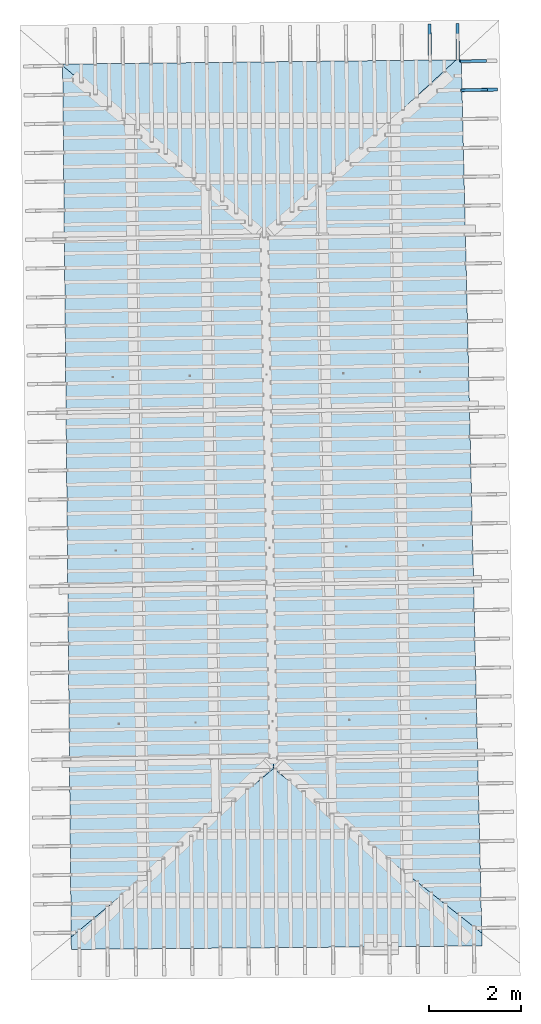
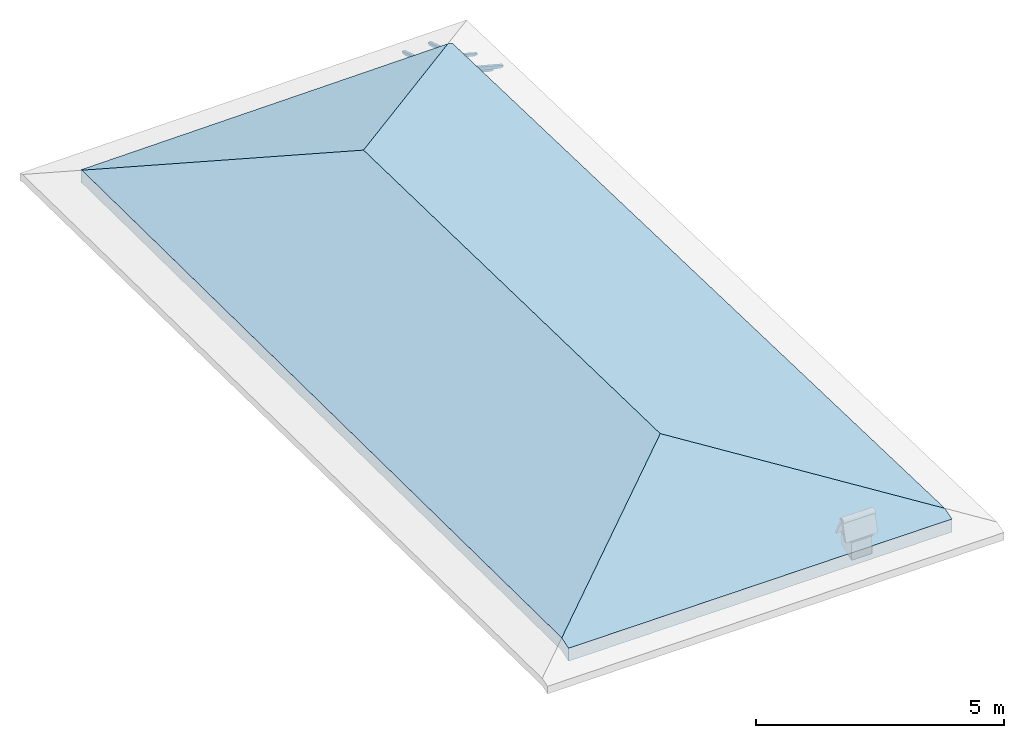
# One storey, part 17 of 19: 5 beams, 1 roof, 3 elements without a shape of their own.
"""IFC4 building model written with IfcOpenShell, lengths in metres."""

from ifc_helpers import new_model, entity, si_unit, converted_unit, derived_unit, direction, frame, origin, place, context, subcontext, project, spatial, line, arc, indexed_curve, outline, extrude, polygons, source, transform, mapped, material, constituent, constituent_set, type_object, type_shapes, element, aggregate, save


model = new_model("IFC4")

# Units and contexts
model_context = context("Model", 3, precision=1e-05, world=origin(), true_north=direction((6.123233995736766e-17, 1.0)))
body_context = subcontext(model_context, "Body", "Model", "MODEL_VIEW")
ifc_project = project(units=[si_unit("LENGTHUNIT", "METRE"), si_unit("AREAUNIT", "SQUARE_METRE"), si_unit("VOLUMEUNIT", "CUBIC_METRE"), converted_unit("PLANEANGLEUNIT", "DEGREE", entity("IfcPlaneAngleMeasure", 0.017453292519943278), si_unit("PLANEANGLEUNIT", "RADIAN"), dimensions=[0, 0, 0, 0, 0, 0, 0]), derived_unit("THERMALTRANSMITTANCEUNIT", [(si_unit("MASSUNIT", "GRAM", prefix="KILO"), 1), (si_unit("THERMODYNAMICTEMPERATUREUNIT", "KELVIN"), -1), (si_unit("TIMEUNIT", "SECOND"), -3)])], contexts=[model_context])

# Site, building, storey
site_placement = place(None, origin())
site = spatial("IfcSite", under=ifc_project, at=site_placement, CompositionType="ELEMENT")
building_placement = place(site_placement, origin())
building = spatial("IfcBuilding", under=site, at=building_placement, CompositionType="ELEMENT")
storey_placement = place(building_placement, frame((0.0, 0.0, 3.28)))
storey = spatial("IfcBuildingStorey", under=building, at=storey_placement, Name="Livello Copertura", CompositionType="ELEMENT", Elevation=3.28)

# Assembly, beams
assembly_1_placement = place(storey_placement, origin())
assembly_1 = element("IfcElementAssembly", 1, at=assembly_1_placement, inside=storey, Name="Sistema di travi strutturali:Sistema di travi strutturali", ObjectType="Sistema di travi strutturali:Sistema di travi strutturali", AssemblyPlace="NOTDEFINED", PredefinedType="BEAM_GRID")
ifc_material_1 = material(Name="Legno - Legno da costruzione", Category="Legno")
beam_type_1 = type_object("IfcBeamType", Name="70x70:70x70", PredefinedType="JOIST", material=ifc_material_1)
shared_shape_1 = source(origin(), body_context, "Body", "SweptSolid", [
    extrude(outline(indexed_curve([(-0.04357142857143151, -0.5561428571428565), (0.026428571428568467, -0.5561428571428565), (0.026428571428568467, 0.1728571428571433), (0.012428571428584355, 0.1728571428571399), (0.026181867029378872, 0.19656674738504454), (0.018428571428570788, 0.22285714285714342), (0.006014118110847752, 0.24585271837212633), (0.0034285714285709526, 0.27185714285714324), (-0.04357142857143151, 0.27185714285714324)], segments=[line(1, 2, 3, 4), arc(4, 5, 6), arc(6, 7, 8), line(8, 9, 1)], self_intersect=False)), frame((-0.10714285714285654, -0.03500000000000078, -0.008571428571433252), z_axis=(0.0, 1.0, 0.0), x_axis=(0.0, 0.0, -1.0)), (0.0, 0.0, 1.0), 0.06999999999999999),
])
type_shapes(beam_type_1, [shared_shape_1])
beam_1_placement = place(assembly_1_placement, frame((3.3021251021480253, 16.58789007106717, 0.1374604616957802), z_axis=(-0.0071866559421429246, 0.30161875858893344, 0.9534015294951231), x_axis=(0.00927665986362566, -0.95336501447268, 0.30167713330857804)))
beam_1 = element("IfcBeam", 2, at=beam_1_placement, type_object=beam_type_1, material=ifc_material_1, Name="70x70:70x70", ObjectType="70x70:70x70", PredefinedType="JOIST", context=body_context, shape_type="MappedRepresentation", body=[
    mapped(shared_shape_1, transform((0.0, 0.0, 0.0), scale=1.0)),
])
beam_type_2 = type_object("IfcBeamType", Name="70x70:70x70", PredefinedType="JOIST", material=ifc_material_1)
shared_shape_2 = source(origin(), body_context, "Body", "SweptSolid", [
    extrude(outline(indexed_curve([(-0.04357142857143156, -0.5382857142857138), (0.026428571428568436, -0.5382857142857138), (0.026428571428568436, 0.16571428571428615), (0.01242857142858434, 0.16571428571428284), (0.026181867029378855, 0.18942389024218748), (0.018428571428570874, 0.21571428571428627), (0.006014118110847837, 0.2387098612292692), (0.0034285714285710416, 0.2647142857142861), (-0.04357142857143156, 0.2647142857142861)], segments=[line(1, 2, 3, 4), arc(4, 5, 6), arc(6, 7, 8), line(8, 9, 1)], self_intersect=False)), frame((-0.1017857142857138, -0.03500000000000078, -0.008571428571433287), z_axis=(0.0, 1.0, 0.0), x_axis=(0.0, 0.0, -1.0)), (0.0, 0.0, 1.0), 0.06999999999999999),
])
type_shapes(beam_type_2, [shared_shape_2])
beam_2_placement = place(assembly_1_placement, frame((3.9105663853880794, 16.606597025008856, 0.13612869326249122), z_axis=(-0.007186655942142926, 0.3016187585889337, 0.953401529495123), x_axis=(0.009276659863625414, -0.9533650144726799, 0.3016771333085783)))
beam_2 = element("IfcBeam", 3, at=beam_2_placement, type_object=beam_type_2, material=ifc_material_1, Name="70x70:70x70", ObjectType="70x70:70x70", PredefinedType="JOIST", context=body_context, shape_type="MappedRepresentation", body=[
    mapped(shared_shape_2, transform((0.0, 0.0, 0.0), scale=1.0)),
])
aggregate(assembly_1, [beam_1, beam_2])

# Assembly, beam
assembly_2_placement = place(storey_placement, origin())
assembly_2 = element("IfcElementAssembly", 4, at=assembly_2_placement, inside=storey, Name="Sistema di travi strutturali:Sistema di travi strutturali", ObjectType="Sistema di travi strutturali:Sistema di travi strutturali", AssemblyPlace="NOTDEFINED", PredefinedType="BEAM_GRID")
beam_type_3 = type_object("IfcBeamType", Name="70x70:70x70", PredefinedType="JOIST", material=ifc_material_1)
shared_shape_3 = source(origin(), body_context, "Body", "SweptSolid", [
    extrude(outline(indexed_curve([(-0.0435714285714315, -0.5368571428571424), (0.026428571428568474, -0.5368571428571424), (0.026428571428568474, 0.1651428571428576), (0.012428571428584369, 0.1651428571428543), (0.026181867029378886, 0.18885246167075892), (0.018428571428570763, 0.21514285714285775), (0.006014118110847727, 0.23813843265784065), (0.0034285714285709284, 0.26414285714285757), (-0.0435714285714315, 0.26414285714285757)], segments=[line(1, 2, 3, 4), arc(4, 5, 6), arc(6, 7, 8), line(8, 9, 1)], self_intersect=False)), frame((-0.10135714285714231, -0.03500000000000078, -0.008571428571433243), z_axis=(0.0, 1.0, 0.0), x_axis=(0.0, 0.0, -1.0)), (0.0, 0.0, 1.0), 0.06999999999999999),
])
type_shapes(beam_type_3, [shared_shape_3])
beam_3_placement = place(assembly_2_placement, frame((4.416403261745781, 15.520283014566122, 0.12801697405298862), z_axis=(0.2688805697492532, 0.004594467440668768, 0.9631625667976583), x_axis=(-0.9630219859926786, -0.016455533263032108, 0.2689198206152651)))
beam_3 = element("IfcBeam", 5, at=beam_3_placement, type_object=beam_type_3, material=ifc_material_1, Name="70x70:70x70", ObjectType="70x70:70x70", PredefinedType="JOIST", context=body_context, shape_type="MappedRepresentation", body=[
    mapped(shared_shape_3, transform((0.0, 0.0, 0.0), scale=1.0)),
])
aggregate(assembly_2, [beam_3])

# Assembly, beams
assembly_3_placement = place(storey_placement, origin())
assembly_3 = element("IfcElementAssembly", 6, at=assembly_3_placement, inside=storey, Name="Sistema di travi strutturali:Sistema di travi strutturali", ObjectType="Sistema di travi strutturali:Sistema di travi strutturali", AssemblyPlace="NOTDEFINED", PredefinedType="BEAM_GRID")
beam_type_4 = type_object("IfcBeamType", Name="60x60:60x60", PredefinedType="JOIST", material=ifc_material_1)
shared_shape_4 = source(origin(), body_context, "Body", "SweptSolid", [
    extrude(outline(indexed_curve([(-0.03585714285711782, -0.3862857142857145), (0.024142857142882158, -0.3862857142857145), (0.024142857142882158, 0.10671428571428558), (0.0071428571428822215, 0.10671428571428558), (0.022800314198399153, 0.12431070176985333), (0.020142857142794162, 0.1477142857142867), (0.0060973625587453645, 0.1758678741622665), (-0.003857142857205052, 0.20571428571428554), (-0.03585714285711782, 0.20571428571428563)], segments=[line(1, 2, 3, 4), arc(4, 5, 6), arc(6, 7, 8), line(8, 9, 1)], self_intersect=False)), frame((0.04971428571428556, -0.030000000000000786, -0.0058571428571195586), z_axis=(0.0, 1.0, 0.0), x_axis=(0.0, 0.0, -1.0)), (0.0, 0.0, 1.0), 0.059999999999999984),
])
type_shapes(beam_type_4, [shared_shape_4])
beam_4_placement = place(assembly_3_placement, frame((4.384478018135656, 16.14982946209549, 0.06644029426000375), z_axis=(0.26888056974925323, 0.004594467440668771, 0.9631625667976583), x_axis=(-0.9630219859926786, -0.01645553326303132, 0.2689198206152652)))
beam_4 = element("IfcBeam", 7, at=beam_4_placement, type_object=beam_type_4, material=ifc_material_1, Name="60x60:60x60", ObjectType="60x60:60x60", PredefinedType="JOIST", context=body_context, shape_type="MappedRepresentation", body=[
    mapped(shared_shape_4, transform((0.0, 0.0, 0.0), scale=1.0)),
])
beam_type_5 = type_object("IfcBeamType", Name="60x60:60x60", PredefinedType="JOIST", material=ifc_material_1)
shared_shape_5 = source(origin(), body_context, "Body", "SweptSolid", [
    extrude(outline(indexed_curve([(-0.03585714285711777, -0.3855714285714288), (0.024142857142882217, -0.3855714285714288), (0.024142857142882217, 0.10642857142857129), (0.00714285714288228, 0.10642857142857129), (0.022800314198399212, 0.12402498748413902), (0.020142857142794016, 0.14742857142857244), (0.00609736255874522, 0.1755821598765522), (-0.003857142857205197, 0.20542857142857127), (-0.03585714285711777, 0.20542857142857132)], segments=[line(1, 2, 3, 4), arc(4, 5, 6), arc(6, 7, 8), line(8, 9, 1)], self_intersect=False)), frame((0.04992857142857128, -0.030000000000000786, -0.0058571428571195005), z_axis=(0.0, 1.0, 0.0), x_axis=(0.0, 0.0, -1.0)), (0.0, 0.0, 1.0), 0.059999999999999984),
])
type_shapes(beam_type_5, [shared_shape_5])
beam_5_placement = place(assembly_3_placement, frame((4.398926024712081, 15.519984374182478, 0.06541140721114114), z_axis=(0.26888056974925295, 0.004594467440668764, 0.9631625667976584), x_axis=(-0.9630219859926787, -0.01645553326303212, 0.26891982061526487)))
beam_5 = element("IfcBeam", 8, at=beam_5_placement, type_object=beam_type_5, material=ifc_material_1, Name="60x60:60x60", ObjectType="60x60:60x60", PredefinedType="JOIST", context=body_context, shape_type="MappedRepresentation", body=[
    mapped(shared_shape_5, transform((0.0, 0.0, 0.0), scale=1.0)),
])
aggregate(assembly_3, [beam_4, beam_5])

# Roof
ifc_material_2 = material(Name="Coppi")
ifc_constituent_1 = constituent(ifc_material_2, Name="Coppi", fraction=0.42052980132450335)
ifc_material_3 = material(Name="Default")
ifc_constituent_2 = constituent(ifc_material_3, Name="Default", fraction=0.33112582781456956)
ifc_material_4 = material(Name="Calcestruzzo", Category="Calcestruzzo")
ifc_constituent_3 = constituent(ifc_material_4, Name="Calcestruzzo", Category="Calcestruzzo", fraction=0.16556291390728478)
ifc_constituent_4 = constituent(ifc_material_3, Name="Default", fraction=0.08278145695364239)
ifc_constituent_set = constituent_set(constituents=[ifc_constituent_1, ifc_constituent_2, ifc_constituent_3, ifc_constituent_4], Name="Tetto di base:Copertura Generica")
roof_type = type_object("IfcRoofType", Name="Tetto di base:Copertura Generica", PredefinedType="NOTDEFINED")
roof_placement = place(storey_placement, frame((-4.701827008581015, -3.220852340332876, 0.011946887846860486)))
element("IfcRoof", 9, at=roof_placement, inside=storey, type_object=roof_type, material=ifc_constituent_set, Name="Tetto di base:Copertura Generica", ObjectType="Tetto di base:Copertura Generica", PredefinedType="NOTDEFINED", context=body_context, shape_type="Tessellation", body=[
    polygons([(4.398964258223519, 15.537057885063565, 1.3532859050342498), (4.596792482175896, 3.9596190946700864, 1.353285905034257), (0.1863903547203538, 0.28682758569555, 0.10453932857954129), (0.00044291295279830223, 19.25751711369629, 0.14312322143276557), (8.594370090775751, 19.397355311588534, 0.16366417250261023), (8.692384376292544, 19.398434761515492, 0.13629693737583048), (9.139804381972759, 0.37320443983377594, 0.10214720407621014), (4.398790940112338, 15.547200926250303, 1.666836296640617), (4.59708280706405, 3.942628502757702, 1.6668362966406196), (9.140206019549174, 0.35612597373899524, 0.415666940334261), (8.692384376292544, 19.398434761515492, 0.4498473289821985), (8.583037583190706, 19.397230504531883, 0.4803787906094388), (0.00034411039878623484, 19.267597126408102, 0.4566941144621244), (0.18655789581255888, 0.26973474476591885, 0.4180549555906583), (3.108624468950438e-14, 19.30270388279097, 0.12882456568254463), (9.146779591435156, 0.07660400874145479, 4.440892098500626e-16), (0.18920178947129873, 3.9968028886505635e-15, 0.005771945404521972), (3.108624468950438e-14, 19.30270388279097, 0.4455851231781094), (0.18920178947129962, 3.9968028886505635e-15, 0.32517339112289667), (9.146779591435156, 0.07660400874145479, 0.31940144571837514)], [[[1, 2, 3, 4]], [[2, 1, 5, 6, 7]], [[8, 9, 10, 11, 12]], [[9, 8, 13, 14]], [[5, 1, 4, 15]], [[3, 2, 7, 16, 17]], [[13, 8, 12, 18]], [[9, 14, 19, 20, 10]], [[6, 11, 10, 20, 16, 7]], [[16, 20, 19, 17]], [[17, 19, 14, 13, 18, 15, 4, 3]], [[11, 6, 5, 15, 18, 12]]], closed=True),
])

save(model, "model.ifc")
